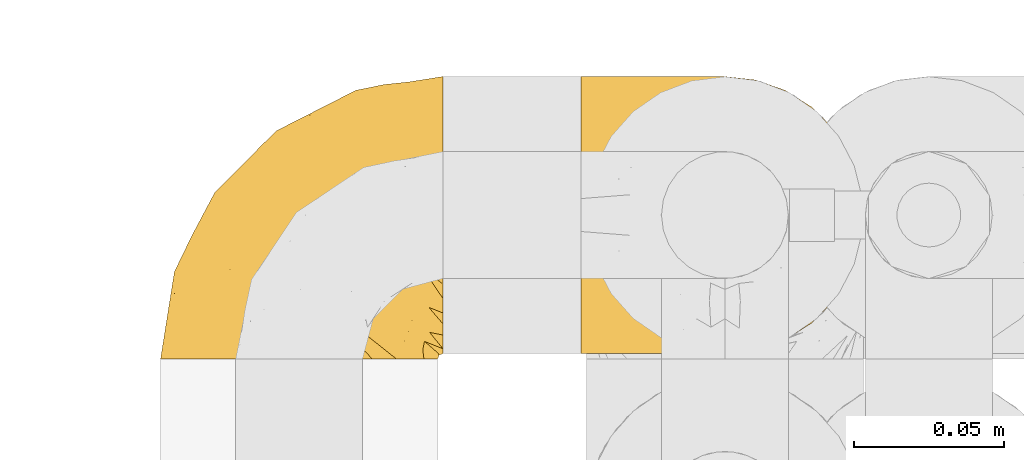
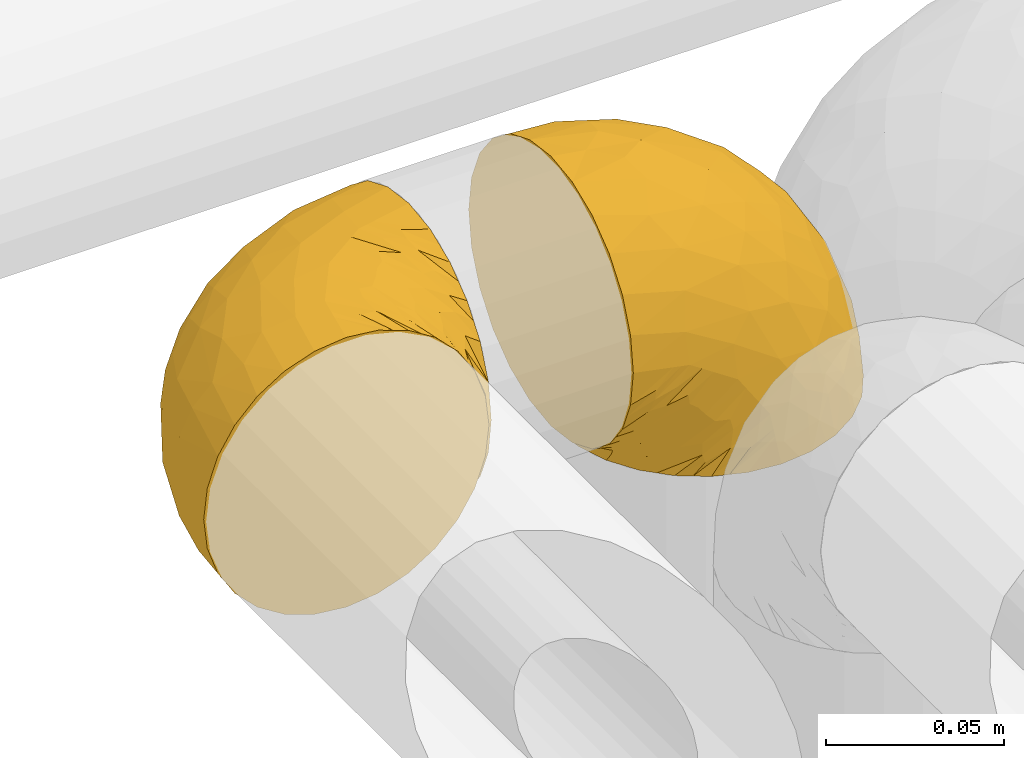
# One storey, part 311 of 827: 2 coverings.
"""IFC2X3 building model written with IfcOpenShell, lengths in millimetres."""

from ifc_helpers import new_model, entity, si_unit, converted_unit, derived_unit, direction, frame, origin, place, context, subcontext, project, spatial, faceted_brep, element, save


model = new_model("IFC2X3")

# Units and contexts
model_context = context("Model", 3, precision=0.01, world=origin(), true_north=direction((6.12303176911189e-17, 1.0)))
body_context = subcontext(model_context, "Body", "Model", "MODEL_VIEW")
ifc_project = project(units=[si_unit("LENGTHUNIT", "METRE", prefix="MILLI"), si_unit("AREAUNIT", "SQUARE_METRE"), si_unit("VOLUMEUNIT", "CUBIC_METRE"), converted_unit("PLANEANGLEUNIT", "DEGREE", entity("IfcRatioMeasure", 0.0174532925199433), si_unit("PLANEANGLEUNIT", "RADIAN"), dimensions=[0, 0, 0, 0, 0, 0, 0]), si_unit("MASSUNIT", "GRAM", prefix="KILO"), derived_unit("MASSDENSITYUNIT", [(si_unit("MASSUNIT", "GRAM", prefix="KILO"), 1), (si_unit("LENGTHUNIT", "METRE"), -3)]), derived_unit("MOMENTOFINERTIAUNIT", [(si_unit("LENGTHUNIT", "METRE"), 4)]), si_unit("TIMEUNIT", "SECOND"), si_unit("FREQUENCYUNIT", "HERTZ"), si_unit("THERMODYNAMICTEMPERATUREUNIT", "DEGREE_CELSIUS"), derived_unit("THERMALTRANSMITTANCEUNIT", [(si_unit("MASSUNIT", "GRAM", prefix="KILO"), 1), (si_unit("THERMODYNAMICTEMPERATUREUNIT", "KELVIN"), -1), (si_unit("TIMEUNIT", "SECOND"), -3)]), derived_unit("VOLUMETRICFLOWRATEUNIT", [(si_unit("LENGTHUNIT", "METRE"), 3), (si_unit("TIMEUNIT", "SECOND"), -1)]), derived_unit("MASSFLOWRATEUNIT", [(si_unit("MASSUNIT", "GRAM", prefix="KILO"), 1), (si_unit("TIMEUNIT", "SECOND"), -1)]), derived_unit("ROTATIONALFREQUENCYUNIT", [(si_unit("TIMEUNIT", "SECOND"), -1)]), si_unit("ELECTRICCURRENTUNIT", "AMPERE"), si_unit("ELECTRICVOLTAGEUNIT", "VOLT"), si_unit("POWERUNIT", "WATT"), si_unit("FORCEUNIT", "NEWTON", prefix="KILO"), si_unit("ILLUMINANCEUNIT", "LUX"), si_unit("LUMINOUSFLUXUNIT", "LUMEN"), si_unit("LUMINOUSINTENSITYUNIT", "CANDELA"), derived_unit("USERDEFINED", [(si_unit("MASSUNIT", "GRAM", prefix="KILO"), -1), (si_unit("LENGTHUNIT", "METRE"), -2), (si_unit("TIMEUNIT", "SECOND"), 3), (si_unit("LUMINOUSFLUXUNIT", "LUMEN"), 1)]), derived_unit("LINEARVELOCITYUNIT", [(si_unit("LENGTHUNIT", "METRE"), 1), (si_unit("TIMEUNIT", "SECOND"), -1)]), si_unit("PRESSUREUNIT", "PASCAL"), derived_unit("USERDEFINED", [(si_unit("LENGTHUNIT", "METRE"), -2), (si_unit("MASSUNIT", "GRAM", prefix="KILO"), 1), (si_unit("TIMEUNIT", "SECOND"), -2)]), derived_unit("LINEARFORCEUNIT", [(si_unit("MASSUNIT", "GRAM", prefix="KILO"), 1), (si_unit("LENGTHUNIT", "METRE"), 1), (si_unit("TIMEUNIT", "SECOND"), -2), (si_unit("LENGTHUNIT", "METRE"), -1)]), derived_unit("PLANARFORCEUNIT", [(si_unit("MASSUNIT", "GRAM", prefix="KILO"), 1), (si_unit("LENGTHUNIT", "METRE"), 1), (si_unit("TIMEUNIT", "SECOND"), -2), (si_unit("LENGTHUNIT", "METRE"), -2)])], contexts=[model_context])

# Site, building, storey
site_placement = place(None, origin())
site = spatial("IfcSite", under=ifc_project, at=site_placement, CompositionType="ELEMENT")
building_placement = place(site_placement, origin())
building = spatial("IfcBuilding", under=site, at=building_placement, CompositionType="ELEMENT")
storey_placement = place(building_placement, frame((0.0, 0.0, 28200.0)))
storey = spatial("IfcBuildingStorey", under=building, at=storey_placement, Name="08", CompositionType="ELEMENT", Elevation=28200.0)

# Coverings
covering_1_placement = place(storey_placement, frame((30467.25, 18391.61, 2952.2)))
element("IfcCovering", 1, at=covering_1_placement, inside=storey, Name=":ADSK_", ObjectType=":ADSK_", PredefinedType="INSULATION", context=body_context, shape_type="Brep", body=[
    faceted_brep([(18.98, 1.6, 83.91), (11.67, 1.6, 76.59), (6.17, 1.6, 67.83), (2.75, 1.6, 58.07), (1.6, 1.6, 47.8), (2.75, 1.6, 37.51), (6.17, 1.6, 27.74), (11.68, 1.6, 18.98), (19.0, 1.6, 11.67), (27.76, 1.6, 6.17), (37.52, 1.6, 2.75), (47.8, 1.6, 1.6), (51.94, 1.6, 2.06), (55.01, 1.6, 2.41), (58.08, 1.6, 2.75), (62.96, 1.6, 4.46), (67.85, 1.6, 6.17), (72.23, 1.6, 8.93), (76.61, 1.6, 11.68), (80.26, 1.6, 15.34), (83.92, 1.6, 19.0), (89.42, 1.6, 27.76), (91.13, 1.6, 32.64), (92.84, 1.6, 37.52), (94.0, 1.6, 47.8), (92.84, 1.6, 58.08), (91.13, 1.6, 62.96), (89.42, 1.6, 67.85), (83.91, 1.6, 76.61), (80.25, 1.6, 80.26), (76.59, 1.6, 83.92), (72.21, 1.6, 86.67), (67.83, 1.6, 89.42), (62.95, 1.6, 91.13), (58.07, 1.6, 92.84), (55.0, 1.6, 93.18), (51.94, 1.6, 93.53), (47.8, 1.6, 94.0), (37.51, 1.6, 92.84), (27.74, 1.6, 89.42), (95.8, 3.4, 47.8), (95.8, 4.97, 35.84), (95.8, 9.58, 24.7), (95.8, 13.26, 19.91), (95.8, 16.93, 15.13), (95.8, 21.71, 11.46), (95.8, 26.5, 7.78), (95.8, 32.07, 5.48), (95.8, 37.64, 3.17), (95.8, 41.25, 2.69), (95.8, 43.34, 2.42), (95.8, 45.42, 2.14), (95.8, 49.6, 1.6), (95.8, 61.55, 3.17), (95.8, 72.7, 7.78), (95.8, 82.26, 15.13), (95.8, 89.61, 24.7), (95.8, 94.22, 35.84), (95.8, 95.8, 47.8), (95.8, 94.22, 59.75), (95.8, 89.61, 70.9), (95.8, 82.26, 80.46), (95.8, 72.7, 87.81), (95.8, 61.55, 92.42), (95.8, 49.6, 94.0), (95.8, 45.42, 93.45), (95.8, 41.25, 92.9), (95.8, 37.64, 92.42), (95.8, 32.07, 90.11), (95.8, 26.5, 87.81), (95.8, 21.71, 84.13), (95.8, 16.93, 80.46), (95.8, 13.26, 75.68), (95.8, 9.58, 70.9), (95.8, 4.97, 59.75), (60.58, 81.55, 71.98), (74.11, 90.4, 63.6), (51.59, 83.0, 59.72), (66.69, 91.18, 47.8), (76.19, 93.13, 55.16), (84.43, 94.0, 47.8), (31.2, 66.19, 63.76), (42.88, 70.92, 72.22), (79.41, 85.95, 74.18), (60.7, 49.74, 92.52), (61.85, 35.54, 94.0), (65.75, 38.14, 94.0), (69.64, 40.74, 94.0), (73.53, 43.34, 94.0), (77.43, 45.94, 94.0), (74.59, 77.59, 82.14), (54.72, 71.17, 80.34), (64.18, 65.81, 87.52), (37.94, 59.03, 79.59), (25.89, 45.85, 78.25), (34.73, 45.79, 85.01), (42.89, 41.42, 90.25), (49.83, 34.51, 93.2), (48.58, 56.04, 87.23), (22.41, 15.15, 85.55), (78.69, 56.51, 93.0), (81.64, 68.39, 89.31), (6.22, 23.33, 61.31), (12.11, 42.86, 56.86), (14.81, 39.42, 68.34), (21.61, 53.58, 65.71), (22.41, 59.17, 56.99), (30.12, 59.06, 72.15), (10.01, 22.63, 70.34), (15.36, 20.55, 78.36), (3.39, 12.96, 47.8), (19.59, 56.96, 47.8), (30.01, 67.38, 47.8), (41.19, 18.72, 93.06), (48.54, 5.33, 94.0), (49.28, 9.07, 94.0), (49.82, 11.79, 94.0), (50.37, 14.51, 94.0), (50.91, 17.24, 94.0), (51.45, 19.96, 94.0), (31.61, 21.03, 89.88), (80.15, 46.48, 94.0), (82.88, 47.03, 94.0), (85.6, 47.57, 94.0), (88.32, 48.11, 94.0), (90.19, 48.48, 94.0), (92.06, 48.85, 94.0), (6.21, 30.7, 47.8), (54.05, 23.86, 94.0), (56.65, 27.75, 94.0), (59.25, 31.64, 94.0), (24.66, 31.26, 83.7), (40.43, 77.8, 47.8), (35.17, 72.75, 55.9), (12.9, 43.83, 47.8), (53.56, 84.49, 47.8), (85.34, 14.58, 81.75), (78.44, 16.17, 86.43), (84.37, 10.82, 79.8), (89.05, 4.64, 69.84), (82.76, 7.71, 79.5), (86.31, 25.13, 88.08), (83.73, 32.66, 91.6), (77.31, 34.94, 92.93), (87.78, 36.76, 92.43), (87.91, 40.48, 93.24), (81.29, 39.25, 93.36), (93.97, 3.69, 57.25), (70.76, 13.99, 89.41), (63.67, 21.85, 92.89), (62.62, 17.93, 92.66), (90.64, 15.11, 79.58), (84.08, 21.14, 86.51), (76.28, 12.7, 86.29), (77.45, 7.21, 83.91), (91.35, 10.45, 73.94), (88.72, 32.27, 90.94), (71.28, 25.68, 91.94), (68.09, 22.18, 91.98), (91.07, 18.79, 82.79), (57.47, 10.12, 93.16), (70.34, 9.47, 88.76), (62.99, 11.29, 91.89), (94.52, 2.87, 47.8), (76.47, 31.16, 92.22), (69.96, 6.31, 88.56), (89.86, 25.62, 87.72), (78.94, 21.18, 88.33), (73.51, 28.81, 92.18), (89.62, 7.45, 71.78), (84.09, 21.14, 9.09), (86.3, 25.13, 7.51), (91.06, 18.79, 12.8), (88.32, 48.11, 1.6), (92.06, 48.85, 1.6), (82.88, 47.03, 1.6), (85.6, 47.57, 1.6), (93.97, 3.69, 38.35), (89.63, 7.44, 23.84), (50.37, 14.51, 1.6), (49.82, 11.79, 1.6), (48.54, 5.33, 1.6), (49.28, 9.07, 1.6), (82.77, 7.71, 16.1), (70.36, 9.47, 6.84), (77.31, 34.94, 2.66), (76.47, 31.16, 3.37), (69.64, 40.74, 1.6), (65.75, 38.14, 1.6), (87.78, 36.76, 3.16), (87.91, 40.48, 2.35), (89.06, 4.63, 25.77), (90.65, 15.11, 16.02), (85.35, 14.58, 13.85), (73.53, 43.34, 1.6), (77.43, 45.94, 1.6), (81.29, 39.25, 2.23), (77.46, 7.21, 11.69), (76.29, 12.69, 9.31), (57.47, 10.14, 2.43), (63.71, 21.81, 2.71), (68.11, 22.19, 3.61), (70.77, 14.0, 6.18), (71.31, 25.69, 3.66), (78.46, 16.17, 9.17), (69.52, 6.66, 6.77), (62.64, 17.92, 2.93), (91.35, 10.45, 21.66), (59.25, 31.64, 1.6), (84.6, 10.64, 16.09), (62.98, 11.31, 3.7), (51.45, 19.96, 1.6), (54.05, 23.86, 1.6), (56.65, 27.75, 1.6), (83.73, 32.66, 3.99), (80.15, 46.48, 1.6), (88.72, 32.27, 4.65), (61.85, 35.54, 1.6), (73.56, 28.77, 3.43), (78.96, 21.17, 7.27), (91.36, 23.36, 9.46), (50.91, 17.24, 1.6), (62.87, 47.58, 2.4), (76.19, 93.13, 40.43), (73.57, 77.44, 13.57), (56.07, 66.78, 11.3), (49.77, 71.68, 18.65), (44.73, 74.96, 27.26), (60.58, 81.55, 23.61), (47.64, 36.7, 3.07), (78.32, 56.9, 2.69), (51.59, 83.0, 35.87), (74.11, 90.4, 31.99), (76.04, 67.83, 6.71), (79.41, 85.95, 21.41), (14.82, 39.41, 27.24), (6.22, 23.33, 34.26), (12.12, 42.87, 38.73), (23.51, 53.92, 26.97), (31.2, 66.19, 31.83), (34.96, 64.12, 23.4), (33.86, 33.13, 6.91), (38.94, 23.1, 3.4), (30.23, 16.98, 5.84), (35.17, 72.75, 39.69), (15.85, 23.77, 17.6), (22.59, 18.41, 10.38), (21.56, 43.7, 20.6), (55.94, 54.53, 5.36), (20.67, 55.72, 35.73), (9.19, 17.73, 24.84), (25.79, 38.98, 13.87), (41.16, 50.28, 9.06), (37.95, 59.02, 15.99)], [[[0, 1, 2, 3, 4, 5, 6, 7, 8, 9, 10, 11, 12, 13, 14, 15, 16, 17, 18, 19, 20, 21, 22, 23, 24, 25, 26, 27, 28, 29, 30, 31, 32, 33, 34, 35, 36, 37, 38, 39]], [[40, 41, 42, 43, 44, 45, 46, 47, 48, 49, 50, 51, 52, 53, 54, 55, 56, 57, 58, 59, 60, 61, 62, 63, 64, 65, 66, 67, 68, 69, 70, 71, 72, 73, 74]], [[75, 76, 77]], [[78, 79, 80]], [[77, 81, 82]], [[76, 75, 83]], [[84, 85, 86, 87, 88, 89]], [[90, 91, 92]], [[76, 60, 59]], [[93, 94, 95]], [[90, 62, 61]], [[83, 61, 60]], [[96, 97, 84]], [[98, 93, 95]], [[0, 39, 99]], [[100, 84, 89]], [[62, 101, 63]], [[2, 102, 3]], [[92, 84, 100]], [[103, 102, 104]], [[103, 105, 106]], [[93, 107, 94]], [[1, 108, 2]], [[92, 101, 90]], [[108, 1, 109]], [[102, 110, 3]], [[93, 82, 107]], [[102, 108, 104]], [[111, 106, 112]], [[109, 0, 99]], [[113, 37, 114, 115, 116, 117, 118, 119]], [[120, 38, 113]], [[100, 89, 121, 122, 123, 124, 125, 126, 64]], [[127, 102, 103]], [[97, 119, 128, 129, 130, 85]], [[99, 120, 131]], [[132, 133, 77]], [[59, 80, 79]], [[1, 0, 109]], [[98, 84, 92]], [[94, 109, 131]], [[120, 39, 38]], [[93, 91, 82]], [[104, 94, 105]], [[97, 113, 119]], [[95, 120, 96]], [[83, 90, 61]], [[91, 93, 98]], [[64, 63, 100]], [[100, 63, 101]], [[77, 76, 79]], [[133, 106, 81]], [[84, 97, 85]], [[113, 96, 120]], [[113, 97, 96]], [[37, 113, 38]], [[110, 102, 127]], [[110, 4, 3]], [[103, 111, 134, 127]], [[90, 75, 91]], [[82, 81, 107]], [[91, 75, 82]], [[77, 82, 75]], [[76, 83, 60]], [[90, 83, 75]], [[105, 107, 81]], [[94, 131, 95]], [[105, 94, 107]], [[109, 94, 104]], [[120, 95, 131]], [[98, 95, 96]], [[84, 98, 96]], [[98, 92, 91]], [[106, 105, 81]], [[103, 104, 105]], [[112, 106, 133]], [[103, 106, 111]], [[112, 133, 132]], [[81, 77, 133]], [[77, 78, 135, 132]], [[120, 99, 39]], [[109, 99, 131]], [[59, 58, 80]], [[59, 79, 76]], [[90, 101, 62]], [[100, 101, 92]], [[2, 108, 102]], [[109, 104, 108]], [[78, 77, 79]], [[136, 137, 138]], [[27, 139, 140]], [[141, 142, 143]], [[144, 145, 121]], [[146, 89, 88]], [[147, 139, 25]], [[148, 149, 150]], [[136, 151, 152]], [[147, 40, 74]], [[24, 147, 25]], [[140, 153, 154]], [[33, 116, 34]], [[73, 151, 155]], [[114, 37, 36, 35, 34, 116, 115]], [[146, 156, 144]], [[157, 85, 130]], [[158, 149, 148]], [[151, 159, 152]], [[117, 33, 160]], [[29, 154, 161]], [[155, 74, 73]], [[162, 128, 119]], [[66, 65, 64, 126, 125, 124, 123, 122, 67]], [[163, 147, 24]], [[27, 140, 28]], [[149, 129, 150]], [[139, 27, 26, 25]], [[68, 144, 69]], [[129, 128, 150]], [[164, 87, 86]], [[130, 129, 149]], [[122, 145, 67]], [[154, 153, 148]], [[162, 119, 160]], [[165, 30, 161]], [[150, 161, 148]], [[128, 162, 150]], [[30, 165, 31]], [[145, 144, 68]], [[89, 146, 144]], [[87, 164, 143]], [[166, 156, 142]], [[88, 87, 143]], [[162, 161, 150]], [[161, 30, 29]], [[154, 29, 28]], [[140, 154, 28]], [[161, 154, 148]], [[140, 137, 153]], [[158, 148, 153]], [[157, 130, 158]], [[153, 137, 158]], [[158, 137, 157]], [[167, 137, 136]], [[168, 85, 157]], [[152, 168, 167]], [[167, 168, 157]], [[164, 152, 141]], [[151, 73, 72]], [[159, 72, 71]], [[88, 142, 146]], [[144, 156, 69]], [[146, 142, 156]], [[70, 166, 71]], [[142, 141, 166]], [[70, 69, 156]], [[141, 159, 71]], [[167, 136, 152]], [[138, 137, 140]], [[155, 136, 169]], [[136, 155, 151]], [[74, 155, 169]], [[152, 159, 141]], [[151, 72, 159]], [[168, 152, 164]], [[137, 167, 157]], [[164, 86, 168]], [[85, 168, 86]], [[116, 33, 117]], [[130, 149, 158]], [[67, 145, 68]], [[121, 89, 144]], [[145, 122, 121]], [[40, 147, 163]], [[169, 147, 74]], [[160, 33, 32]], [[162, 160, 32]], [[160, 119, 118, 117]], [[139, 147, 169]], [[139, 169, 138]], [[162, 32, 31]], [[141, 143, 164]], [[88, 143, 142]], [[71, 166, 141]], [[156, 166, 70]], [[139, 138, 140]], [[169, 136, 138]], [[161, 162, 165]], [[162, 31, 165]], [[170, 171, 172]], [[173, 174, 52, 51, 50, 49, 48, 175, 176]], [[177, 178, 41]], [[179, 15, 180]], [[12, 11, 181, 182, 180, 14, 13]], [[183, 21, 20]], [[19, 18, 184]], [[185, 186, 187]], [[186, 188, 187]], [[43, 172, 44]], [[189, 190, 47]], [[23, 22, 21, 191]], [[170, 192, 193]], [[40, 163, 177]], [[194, 195, 196]], [[24, 23, 177]], [[197, 198, 183]], [[199, 15, 179]], [[178, 177, 191]], [[47, 46, 189]], [[200, 201, 202]], [[201, 203, 204]], [[205, 206, 184]], [[207, 41, 178]], [[16, 15, 199]], [[14, 180, 15]], [[202, 201, 198]], [[208, 201, 200]], [[163, 24, 177]], [[48, 47, 190]], [[196, 195, 189]], [[197, 184, 202]], [[204, 193, 209]], [[210, 211, 212]], [[206, 212, 213]], [[205, 17, 210]], [[184, 206, 202]], [[210, 212, 206]], [[185, 194, 214]], [[189, 215, 190]], [[216, 45, 214]], [[186, 171, 170]], [[189, 216, 196]], [[197, 20, 19]], [[194, 185, 187]], [[197, 183, 20]], [[184, 197, 19]], [[197, 202, 198]], [[206, 200, 202]], [[204, 183, 198]], [[201, 208, 203]], [[203, 208, 217]], [[204, 198, 201]], [[217, 188, 218]], [[193, 219, 170]], [[171, 186, 185]], [[170, 218, 186]], [[170, 219, 218]], [[42, 207, 192]], [[171, 220, 172]], [[216, 189, 46]], [[214, 194, 196]], [[44, 220, 45]], [[214, 196, 216]], [[216, 46, 45]], [[214, 45, 220]], [[192, 43, 42]], [[204, 203, 219]], [[207, 193, 192]], [[209, 193, 178]], [[41, 207, 42]], [[193, 207, 178]], [[43, 192, 172]], [[170, 172, 192]], [[204, 219, 193]], [[219, 203, 218]], [[217, 218, 203]], [[188, 186, 218]], [[206, 213, 200]], [[208, 200, 213]], [[199, 210, 16]], [[215, 189, 195]], [[215, 175, 190]], [[175, 48, 190]], [[199, 179, 221, 211]], [[210, 199, 211]], [[23, 191, 177]], [[40, 177, 41]], [[191, 183, 209]], [[21, 183, 191]], [[205, 18, 17]], [[17, 16, 210]], [[171, 185, 214]], [[172, 220, 44]], [[214, 220, 171]], [[191, 209, 178]], [[204, 209, 183]], [[206, 205, 210]], [[18, 205, 184]], [[222, 195, 194, 187, 188, 217]], [[57, 223, 80]], [[224, 225, 226]], [[226, 227, 228]], [[229, 217, 208, 213, 212, 211]], [[230, 52, 174, 173, 176, 175, 215, 195]], [[231, 232, 228]], [[231, 78, 223]], [[223, 57, 232]], [[224, 233, 225]], [[233, 54, 53]], [[234, 232, 56]], [[56, 55, 234]], [[234, 224, 228]], [[235, 236, 237]], [[224, 55, 54]], [[238, 239, 240]], [[52, 230, 53]], [[241, 242, 243]], [[231, 227, 244]], [[11, 10, 242]], [[236, 6, 5]], [[7, 245, 8]], [[8, 246, 9]], [[238, 247, 235]], [[222, 229, 248]], [[242, 211, 221, 179, 180, 182, 181, 11]], [[233, 53, 230]], [[111, 112, 249]], [[250, 6, 236]], [[246, 251, 241]], [[6, 250, 7]], [[127, 236, 110]], [[248, 229, 252]], [[246, 8, 245]], [[235, 245, 250]], [[236, 5, 110]], [[235, 249, 238]], [[237, 236, 127]], [[243, 9, 246]], [[252, 229, 241]], [[56, 232, 57]], [[222, 230, 195]], [[225, 248, 252]], [[248, 233, 230]], [[54, 233, 224]], [[231, 228, 227]], [[244, 132, 231]], [[248, 225, 233]], [[226, 225, 253]], [[235, 250, 236]], [[245, 7, 250]], [[251, 246, 245]], [[243, 246, 241]], [[247, 245, 235]], [[252, 251, 253]], [[229, 222, 217]], [[230, 222, 248]], [[5, 4, 110]], [[237, 127, 134, 111]], [[238, 249, 239]], [[224, 234, 55]], [[232, 234, 228]], [[242, 241, 229]], [[10, 9, 243]], [[211, 242, 229]], [[10, 243, 242]], [[80, 223, 78]], [[80, 58, 57]], [[231, 223, 232]], [[227, 240, 239]], [[224, 226, 228]], [[240, 226, 253]], [[227, 239, 244]], [[226, 240, 227]], [[251, 247, 253]], [[240, 253, 247]], [[249, 235, 237]], [[237, 111, 249]], [[244, 239, 249]], [[112, 244, 249]], [[135, 78, 231, 132]], [[112, 132, 244]], [[247, 238, 240]], [[245, 247, 251]], [[251, 252, 241]], [[225, 252, 253]]]),
])
covering_2_placement = place(storey_placement, frame((30607.45, 18393.41, 2950.4)))
element("IfcCovering", 2, at=covering_2_placement, inside=storey, Name=":ADSK_", ObjectType=":ADSK_", PredefinedType="INSULATION", context=body_context, shape_type="Brep", body=[
    faceted_brep([(78.41, 83.91, 1.6), (85.72, 76.59, 1.6), (91.22, 67.83, 1.6), (94.64, 58.07, 1.6), (95.8, 47.8, 1.6), (94.64, 37.51, 1.6), (91.22, 27.74, 1.6), (85.71, 18.98, 1.6), (78.39, 11.67, 1.6), (69.63, 6.17, 1.6), (59.87, 2.75, 1.6), (49.6, 1.6, 1.6), (45.45, 2.06, 1.6), (42.38, 2.41, 1.6), (39.31, 2.75, 1.6), (34.43, 4.46, 1.6), (29.54, 6.17, 1.6), (25.16, 8.93, 1.6), (20.78, 11.68, 1.6), (17.13, 15.34, 1.6), (13.47, 19.0, 1.6), (7.97, 27.76, 1.6), (6.26, 32.64, 1.6), (4.55, 37.52, 1.6), (3.4, 47.8, 1.6), (4.55, 58.08, 1.6), (6.26, 62.96, 1.6), (7.97, 67.85, 1.6), (13.48, 76.61, 1.6), (17.14, 80.26, 1.6), (20.8, 83.92, 1.6), (25.18, 86.67, 1.6), (29.56, 89.42, 1.6), (34.44, 91.13, 1.6), (39.32, 92.84, 1.6), (42.39, 93.18, 1.6), (45.45, 93.53, 1.6), (49.6, 94.0, 1.6), (59.88, 92.84, 1.6), (69.65, 89.42, 1.6), (1.6, 47.8, 3.4), (1.6, 35.84, 4.97), (1.6, 24.7, 9.58), (1.6, 19.91, 13.26), (1.6, 15.13, 16.93), (1.6, 11.46, 21.71), (1.6, 7.78, 26.5), (1.6, 5.48, 32.07), (1.6, 3.17, 37.64), (1.6, 2.69, 41.25), (1.6, 2.42, 43.34), (1.6, 2.14, 45.42), (1.6, 1.6, 49.6), (1.6, 3.17, 61.55), (1.6, 7.78, 72.7), (1.6, 15.13, 82.26), (1.6, 24.7, 89.61), (1.6, 35.84, 94.22), (1.6, 47.8, 95.8), (1.6, 59.75, 94.22), (1.6, 70.9, 89.61), (1.6, 80.46, 82.26), (1.6, 87.81, 72.7), (1.6, 92.42, 61.55), (1.6, 94.0, 49.6), (1.6, 93.45, 45.42), (1.6, 92.9, 41.25), (1.6, 92.42, 37.64), (1.6, 90.11, 32.07), (1.6, 87.81, 26.5), (1.6, 84.13, 21.71), (1.6, 80.46, 16.93), (1.6, 75.68, 13.26), (1.6, 70.9, 9.58), (1.6, 59.75, 4.97), (36.81, 71.98, 81.55), (23.28, 63.6, 90.4), (45.8, 59.72, 83.0), (30.7, 47.8, 91.18), (21.2, 55.16, 93.13), (12.96, 47.8, 94.0), (66.19, 63.76, 66.19), (54.51, 72.22, 70.92), (17.98, 74.18, 85.95), (36.69, 92.52, 49.74), (35.54, 94.0, 35.54), (31.64, 94.0, 38.14), (27.75, 94.0, 40.74), (23.86, 94.0, 43.34), (19.96, 94.0, 45.94), (22.8, 82.14, 77.59), (42.67, 80.34, 71.17), (33.21, 87.52, 65.81), (59.45, 79.59, 59.03), (71.5, 78.25, 45.85), (62.66, 85.01, 45.79), (54.5, 90.25, 41.42), (47.57, 93.2, 34.51), (48.81, 87.23, 56.04), (74.98, 85.55, 15.15), (18.7, 93.0, 56.51), (15.75, 89.31, 68.39), (91.17, 61.31, 23.33), (85.28, 56.86, 42.86), (82.58, 68.34, 39.42), (75.78, 65.71, 53.58), (74.98, 56.99, 59.17), (67.27, 72.15, 59.06), (87.38, 70.34, 22.63), (82.04, 78.36, 20.55), (94.0, 47.8, 12.96), (77.8, 47.8, 56.96), (67.38, 47.8, 67.38), (56.2, 93.06, 18.72), (48.85, 94.0, 5.33), (48.11, 94.0, 9.07), (47.57, 94.0, 11.79), (47.03, 94.0, 14.51), (46.48, 94.0, 17.24), (45.94, 94.0, 19.96), (65.78, 89.88, 21.03), (17.24, 94.0, 46.48), (14.51, 94.0, 47.03), (11.79, 94.0, 47.57), (9.07, 94.0, 48.11), (7.2, 94.0, 48.48), (5.33, 94.0, 48.85), (91.18, 47.8, 30.7), (43.34, 94.0, 23.86), (40.74, 94.0, 27.75), (38.14, 94.0, 31.64), (72.73, 83.7, 31.26), (56.96, 47.8, 77.8), (62.23, 55.9, 72.75), (84.49, 47.8, 43.83), (43.83, 47.8, 84.49), (12.05, 81.75, 14.58), (18.95, 86.43, 16.17), (13.02, 79.8, 10.82), (8.34, 69.84, 4.64), (14.63, 79.5, 7.71), (11.09, 88.08, 25.13), (13.66, 91.6, 32.66), (20.08, 92.93, 34.94), (9.61, 92.43, 36.76), (9.48, 93.24, 40.48), (16.1, 93.36, 39.25), (3.42, 57.25, 3.69), (26.63, 89.41, 13.99), (33.72, 92.89, 21.85), (34.77, 92.66, 17.93), (6.75, 79.58, 15.11), (13.31, 86.51, 21.14), (21.11, 86.29, 12.7), (19.94, 83.91, 7.21), (8.67, 90.94, 32.27), (26.11, 91.94, 25.68), (29.3, 91.98, 22.18), (6.32, 82.79, 18.79), (39.92, 93.16, 10.12), (27.05, 88.76, 9.47), (6.04, 73.94, 10.45), (34.4, 91.89, 11.29), (2.87, 47.8, 2.87), (20.92, 92.22, 31.16), (27.43, 88.56, 6.31), (7.54, 87.72, 25.62), (18.45, 88.33, 21.18), (23.88, 92.18, 28.81), (7.77, 71.78, 7.45), (13.3, 9.09, 21.14), (11.09, 7.51, 25.13), (6.33, 12.8, 18.79), (9.07, 1.6, 48.11), (5.33, 1.6, 48.85), (14.51, 1.6, 47.03), (11.79, 1.6, 47.57), (3.42, 38.35, 3.69), (7.76, 23.84, 7.44), (47.03, 1.6, 14.51), (47.57, 1.6, 11.79), (48.85, 1.6, 5.33), (48.11, 1.6, 9.07), (14.62, 16.1, 7.71), (27.03, 6.84, 9.47), (20.08, 2.66, 34.94), (20.92, 3.37, 31.16), (27.75, 1.6, 40.74), (31.64, 1.6, 38.14), (9.61, 3.16, 36.76), (9.48, 2.35, 40.48), (8.33, 25.77, 4.63), (6.74, 16.02, 15.11), (12.04, 13.85, 14.58), (23.86, 1.6, 43.34), (19.96, 1.6, 45.94), (16.1, 2.23, 39.25), (19.93, 11.69, 7.21), (21.1, 9.31, 12.69), (39.92, 2.43, 10.14), (33.68, 2.71, 21.81), (29.28, 3.61, 22.19), (26.62, 6.18, 14.0), (26.08, 3.66, 25.69), (18.93, 9.17, 16.17), (27.87, 6.77, 6.66), (34.75, 2.93, 17.92), (6.04, 21.66, 10.45), (38.14, 1.6, 31.64), (12.79, 16.09, 10.64), (34.41, 3.7, 11.31), (45.94, 1.6, 19.96), (43.34, 1.6, 23.86), (40.74, 1.6, 27.75), (13.66, 3.99, 32.66), (17.24, 1.6, 46.48), (8.67, 4.65, 32.27), (35.54, 1.6, 35.54), (23.83, 3.43, 28.77), (18.43, 7.27, 21.17), (6.03, 9.46, 23.36), (46.48, 1.6, 17.24), (34.52, 2.4, 47.58), (21.2, 40.43, 93.13), (23.82, 13.57, 77.44), (41.32, 11.3, 66.78), (47.62, 18.65, 71.68), (52.66, 27.26, 74.96), (36.81, 23.61, 81.55), (49.75, 3.07, 36.7), (19.07, 2.69, 56.9), (45.8, 35.87, 83.0), (23.28, 31.99, 90.4), (21.35, 6.71, 67.83), (17.98, 21.41, 85.95), (82.57, 27.24, 39.41), (91.17, 34.26, 23.33), (85.27, 38.73, 42.87), (73.89, 26.97, 53.92), (66.19, 31.83, 66.19), (62.43, 23.4, 64.12), (63.53, 6.91, 33.13), (58.45, 3.4, 23.1), (67.16, 5.84, 16.98), (62.22, 39.69, 72.75), (81.54, 17.6, 23.77), (74.8, 10.38, 18.41), (75.83, 20.6, 43.7), (41.45, 5.36, 54.53), (76.72, 35.73, 55.72), (88.2, 24.84, 17.73), (71.6, 13.87, 38.98), (56.23, 9.06, 50.28), (59.44, 15.99, 59.02)], [[[0, 1, 2, 3, 4, 5, 6, 7, 8, 9, 10, 11, 12, 13, 14, 15, 16, 17, 18, 19, 20, 21, 22, 23, 24, 25, 26, 27, 28, 29, 30, 31, 32, 33, 34, 35, 36, 37, 38, 39]], [[40, 41, 42, 43, 44, 45, 46, 47, 48, 49, 50, 51, 52, 53, 54, 55, 56, 57, 58, 59, 60, 61, 62, 63, 64, 65, 66, 67, 68, 69, 70, 71, 72, 73, 74]], [[75, 76, 77]], [[78, 79, 80]], [[77, 81, 82]], [[76, 75, 83]], [[84, 85, 86, 87, 88, 89]], [[90, 91, 92]], [[76, 60, 59]], [[93, 94, 95]], [[90, 62, 61]], [[83, 61, 60]], [[96, 97, 84]], [[98, 93, 95]], [[0, 39, 99]], [[100, 84, 89]], [[62, 101, 63]], [[2, 102, 3]], [[92, 84, 100]], [[103, 102, 104]], [[103, 105, 106]], [[93, 107, 94]], [[1, 108, 2]], [[92, 101, 90]], [[108, 1, 109]], [[102, 110, 3]], [[93, 82, 107]], [[102, 108, 104]], [[111, 106, 112]], [[109, 0, 99]], [[113, 37, 114, 115, 116, 117, 118, 119]], [[120, 38, 113]], [[100, 89, 121, 122, 123, 124, 125, 126, 64]], [[127, 102, 103]], [[97, 119, 128, 129, 130, 85]], [[99, 120, 131]], [[132, 133, 77]], [[59, 80, 79]], [[1, 0, 109]], [[98, 84, 92]], [[94, 109, 131]], [[120, 39, 38]], [[93, 91, 82]], [[104, 94, 105]], [[97, 113, 119]], [[95, 120, 96]], [[83, 90, 61]], [[91, 93, 98]], [[64, 63, 100]], [[100, 63, 101]], [[77, 76, 79]], [[133, 106, 81]], [[84, 97, 85]], [[113, 96, 120]], [[113, 97, 96]], [[37, 113, 38]], [[110, 102, 127]], [[110, 4, 3]], [[103, 111, 134, 127]], [[90, 75, 91]], [[82, 81, 107]], [[91, 75, 82]], [[77, 82, 75]], [[76, 83, 60]], [[90, 83, 75]], [[105, 107, 81]], [[94, 131, 95]], [[105, 94, 107]], [[109, 94, 104]], [[120, 95, 131]], [[98, 95, 96]], [[84, 98, 96]], [[98, 92, 91]], [[106, 105, 81]], [[103, 104, 105]], [[112, 106, 133]], [[103, 106, 111]], [[112, 133, 132]], [[81, 77, 133]], [[77, 78, 135, 132]], [[120, 99, 39]], [[109, 99, 131]], [[59, 58, 80]], [[59, 79, 76]], [[90, 101, 62]], [[100, 101, 92]], [[2, 108, 102]], [[109, 104, 108]], [[78, 77, 79]], [[136, 137, 138]], [[27, 139, 140]], [[141, 142, 143]], [[144, 145, 121]], [[146, 89, 88]], [[147, 139, 25]], [[148, 149, 150]], [[136, 151, 152]], [[147, 40, 74]], [[24, 147, 25]], [[140, 153, 154]], [[33, 116, 34]], [[73, 72, 151]], [[114, 37, 36, 35, 34, 116, 115]], [[146, 155, 144]], [[156, 85, 130]], [[157, 149, 148]], [[151, 158, 152]], [[117, 33, 159]], [[29, 154, 160]], [[161, 74, 73]], [[162, 128, 119]], [[66, 65, 64, 126, 125, 124, 123, 122, 67]], [[163, 147, 24]], [[27, 140, 28]], [[149, 129, 150]], [[139, 27, 26, 25]], [[68, 144, 69]], [[129, 128, 150]], [[164, 87, 86]], [[130, 129, 149]], [[122, 145, 67]], [[154, 153, 148]], [[162, 119, 159]], [[165, 30, 160]], [[150, 160, 148]], [[128, 162, 150]], [[30, 165, 31]], [[145, 144, 68]], [[89, 146, 144]], [[87, 164, 143]], [[166, 155, 142]], [[88, 87, 143]], [[162, 160, 150]], [[160, 30, 29]], [[154, 29, 28]], [[140, 154, 28]], [[160, 154, 148]], [[140, 137, 153]], [[157, 148, 153]], [[156, 130, 157]], [[153, 137, 157]], [[157, 137, 156]], [[167, 137, 136]], [[168, 85, 156]], [[152, 168, 167]], [[167, 168, 156]], [[164, 152, 141]], [[71, 158, 72]], [[152, 167, 136]], [[88, 142, 146]], [[144, 155, 69]], [[146, 142, 155]], [[70, 166, 71]], [[142, 141, 166]], [[70, 69, 155]], [[141, 158, 71]], [[161, 73, 151]], [[138, 137, 140]], [[161, 136, 169]], [[136, 161, 151]], [[74, 161, 169]], [[152, 158, 141]], [[151, 72, 158]], [[168, 152, 164]], [[137, 167, 156]], [[164, 86, 168]], [[85, 168, 86]], [[116, 33, 117]], [[130, 149, 157]], [[67, 145, 68]], [[121, 89, 144]], [[145, 122, 121]], [[40, 147, 163]], [[169, 147, 74]], [[159, 33, 32]], [[162, 159, 32]], [[159, 119, 118, 117]], [[139, 147, 169]], [[139, 169, 138]], [[162, 32, 31]], [[141, 143, 164]], [[88, 143, 142]], [[71, 166, 141]], [[155, 166, 70]], [[139, 138, 140]], [[169, 136, 138]], [[160, 162, 165]], [[162, 31, 165]], [[170, 171, 172]], [[173, 174, 52, 51, 50, 49, 48, 175, 176]], [[177, 178, 41]], [[179, 15, 180]], [[12, 11, 181, 182, 180, 14, 13]], [[183, 21, 20]], [[19, 18, 184]], [[185, 186, 187]], [[186, 188, 187]], [[43, 172, 44]], [[189, 190, 47]], [[23, 22, 21, 191]], [[170, 192, 193]], [[40, 163, 177]], [[194, 195, 196]], [[24, 23, 177]], [[197, 198, 183]], [[199, 15, 179]], [[47, 46, 189]], [[200, 201, 202]], [[201, 203, 204]], [[205, 206, 184]], [[207, 41, 178]], [[16, 15, 199]], [[14, 180, 15]], [[202, 201, 198]], [[208, 201, 200]], [[163, 24, 177]], [[48, 47, 190]], [[196, 195, 189]], [[197, 184, 202]], [[204, 193, 209]], [[210, 211, 212]], [[206, 212, 213]], [[205, 17, 210]], [[184, 206, 202]], [[210, 212, 206]], [[185, 194, 214]], [[189, 215, 190]], [[216, 45, 214]], [[186, 171, 170]], [[189, 216, 196]], [[197, 20, 19]], [[194, 185, 187]], [[197, 183, 20]], [[184, 197, 19]], [[197, 202, 198]], [[206, 200, 202]], [[204, 183, 198]], [[201, 208, 203]], [[203, 208, 217]], [[204, 198, 201]], [[217, 188, 218]], [[193, 219, 170]], [[171, 186, 185]], [[170, 218, 186]], [[170, 219, 218]], [[42, 207, 192]], [[171, 220, 172]], [[216, 189, 46]], [[214, 194, 196]], [[44, 220, 45]], [[214, 196, 216]], [[216, 46, 45]], [[214, 45, 220]], [[192, 43, 42]], [[204, 203, 219]], [[207, 193, 192]], [[209, 193, 178]], [[41, 207, 42]], [[193, 207, 178]], [[43, 192, 172]], [[170, 172, 192]], [[204, 219, 193]], [[219, 203, 218]], [[217, 218, 203]], [[188, 186, 218]], [[206, 213, 200]], [[208, 200, 213]], [[199, 210, 16]], [[215, 189, 195]], [[215, 175, 190]], [[175, 48, 190]], [[199, 179, 221, 211]], [[210, 199, 211]], [[23, 191, 177]], [[40, 177, 41]], [[178, 177, 191]], [[21, 183, 191]], [[209, 191, 183]], [[205, 18, 17]], [[17, 16, 210]], [[171, 185, 214]], [[172, 220, 44]], [[214, 220, 171]], [[191, 209, 178]], [[204, 209, 183]], [[206, 205, 210]], [[18, 205, 184]], [[222, 195, 194, 187, 188, 217]], [[57, 223, 80]], [[224, 225, 226]], [[226, 227, 228]], [[229, 217, 208, 213, 212, 211]], [[230, 52, 174, 173, 176, 175, 215, 195]], [[231, 232, 228]], [[231, 78, 223]], [[223, 57, 232]], [[224, 233, 225]], [[233, 54, 53]], [[234, 232, 56]], [[56, 55, 234]], [[234, 224, 228]], [[235, 236, 237]], [[224, 55, 54]], [[238, 239, 240]], [[52, 230, 53]], [[241, 242, 243]], [[227, 244, 231]], [[11, 10, 242]], [[236, 6, 5]], [[7, 245, 8]], [[8, 246, 9]], [[238, 247, 235]], [[222, 229, 248]], [[242, 211, 221, 179, 180, 182, 181, 11]], [[233, 53, 230]], [[111, 112, 249]], [[250, 6, 236]], [[246, 251, 241]], [[6, 250, 7]], [[127, 236, 110]], [[248, 229, 252]], [[246, 8, 245]], [[235, 245, 250]], [[236, 5, 110]], [[235, 249, 238]], [[237, 236, 127]], [[243, 9, 246]], [[252, 229, 241]], [[56, 232, 57]], [[222, 230, 195]], [[225, 248, 252]], [[248, 233, 230]], [[54, 233, 224]], [[231, 228, 227]], [[244, 132, 231]], [[248, 225, 233]], [[226, 225, 253]], [[235, 250, 236]], [[245, 7, 250]], [[251, 246, 245]], [[243, 246, 241]], [[247, 245, 235]], [[252, 251, 253]], [[229, 222, 217]], [[230, 222, 248]], [[5, 4, 110]], [[237, 127, 134, 111]], [[238, 249, 239]], [[224, 234, 55]], [[232, 234, 228]], [[242, 241, 229]], [[10, 9, 243]], [[211, 242, 229]], [[10, 243, 242]], [[80, 223, 78]], [[80, 58, 57]], [[231, 223, 232]], [[227, 240, 239]], [[224, 226, 228]], [[240, 226, 253]], [[227, 239, 244]], [[226, 240, 227]], [[251, 247, 253]], [[240, 253, 247]], [[249, 235, 237]], [[237, 111, 249]], [[112, 132, 244]], [[112, 244, 249]], [[78, 231, 132, 135]], [[249, 244, 239]], [[247, 238, 240]], [[245, 247, 251]], [[251, 252, 241]], [[225, 252, 253]]]),
])

save(model, "model.ifc")
